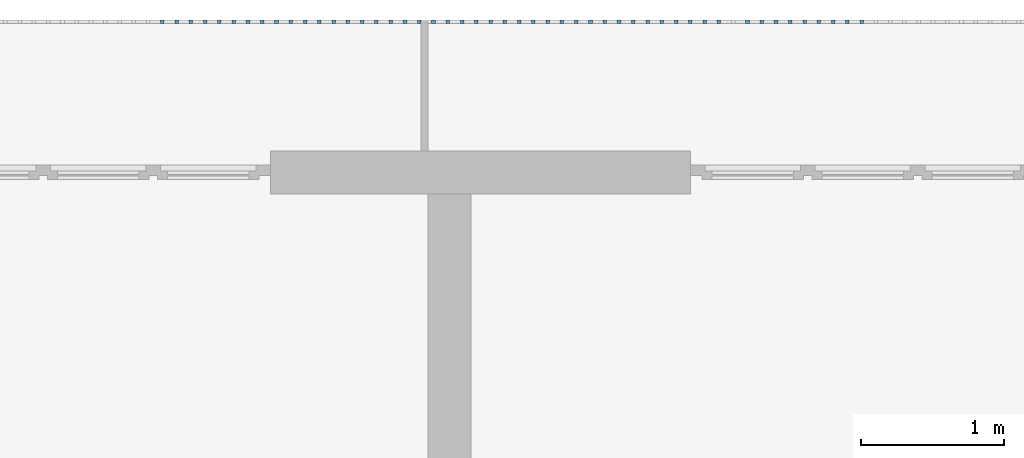
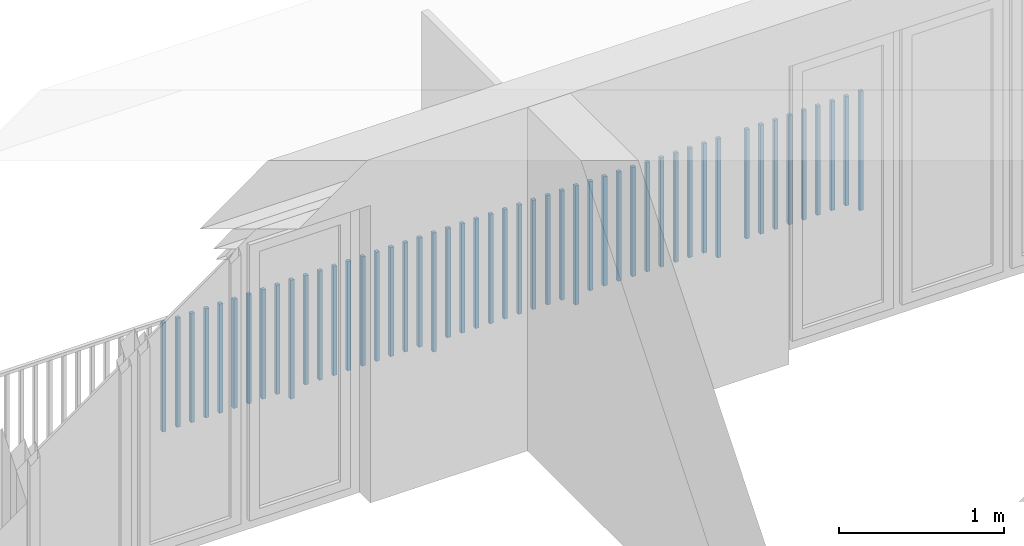
# One storey, part 50 of 54: 49 building element parts, 1 element without a shape of its own.
"""IFC4 building model written with IfcOpenShell, lengths in metres."""

from ifc_helpers import new_model, entity, si_unit, converted_unit, derived_unit, direction, frame, origin_with_axes, place, context, subcontext, project, spatial, polygons, material, type_object, element, aggregate, save


model = new_model("IFC4")

# Units and contexts
model_context = context("Model", 3, precision=1e-05, world=origin_with_axes(), true_north=direction((0.0, 1.0)))
body_context = subcontext(model_context, "Body", "Model", "MODEL_VIEW")
ifc_project = project(units=[si_unit("LENGTHUNIT", "METRE"), si_unit("AREAUNIT", "SQUARE_METRE"), si_unit("VOLUMEUNIT", "CUBIC_METRE"), converted_unit("PLANEANGLEUNIT", "DEGREE", entity("IfcPlaneAngleMeasure", 0.0174532925199), si_unit("PLANEANGLEUNIT", "RADIAN"), dimensions=[0, 0, 0, 0, 0, 0, 0]), converted_unit("TIMEUNIT", "Year", entity("IfcTimeMeasure", 31556926.0), si_unit("TIMEUNIT", "SECOND"), dimensions=[0, 0, 1, 0, 0, 0, 0]), si_unit("MASSUNIT", "GRAM", prefix="KILO"), si_unit("THERMODYNAMICTEMPERATUREUNIT", "DEGREE_CELSIUS"), si_unit("LUMINOUSINTENSITYUNIT", "LUMEN"), si_unit("ENERGYUNIT", "JOULE", prefix="MEGA"), derived_unit("THERMALCONDUCTANCEUNIT", [(si_unit("POWERUNIT", "WATT"), 1), (si_unit("LENGTHUNIT", "METRE"), -1), (si_unit("THERMODYNAMICTEMPERATUREUNIT", "KELVIN"), -1)]), derived_unit("SPECIFICHEATCAPACITYUNIT", [(si_unit("ENERGYUNIT", "JOULE"), 1), (si_unit("MASSUNIT", "GRAM", prefix="KILO"), -1), (si_unit("THERMODYNAMICTEMPERATUREUNIT", "KELVIN"), -1)]), derived_unit("MASSDENSITYUNIT", [(si_unit("MASSUNIT", "GRAM", prefix="KILO"), 1), (si_unit("VOLUMEUNIT", "CUBIC_METRE"), -1)])], contexts=[model_context])

# Site, building, storey, space
site_placement = place(None, origin_with_axes())
site = spatial("IfcSite", under=ifc_project, at=site_placement, CompositionType="ELEMENT")
building_placement = place(site_placement, origin_with_axes())
building = spatial("IfcBuilding", under=site, at=building_placement, CompositionType="ELEMENT")
storey_placement = place(building_placement, frame((0.0, 0.0, 6.29), z_axis=(0.0, 0.0, 1.0), x_axis=(1.0, 0.0, 0.0)))
storey = spatial("IfcBuildingStorey", under=building, at=storey_placement, Name="2. Geschoss", CompositionType="ELEMENT", Elevation=6.29)
space_placement = place(storey_placement, frame((10.2378006196, 9.82118769833, 0.0), z_axis=(0.0, 0.0, 1.0), x_axis=(-1.0, 0.0, 0.0)))
space = spatial("IfcSpace", under=storey, at=space_placement, CompositionType="ELEMENT", PredefinedType="EXTERNAL")

# Railing, building element parts
railing_type = type_object("IfcRailingType", PredefinedType="NOTDEFINED")
railing_placement = place(space_placement, frame((0.0, -7.06315681498e-08, 0.0), z_axis=(0.0, 0.0, 1.0), x_axis=(-1.0, 0.0, 0.0)))
railing = element("IfcRailing", 1, at=railing_placement, inside=space, type_object=railing_type, PredefinedType="NOTDEFINED")
ifc_material = material()
building_element_part_1_placement = place(railing_placement, origin_with_axes())
building_element_part_1 = element("IfcBuildingElementPart", 2, at=building_element_part_1_placement, material=ifc_material, PredefinedType="NOTDEFINED", context=body_context, shape_type="Tessellation", body=[
    polygons([(-7.97076086957, 0.0125, 0.0), (-7.97076086957, -0.0125, 0.0), (-7.97076086957, -0.0125, 0.88), (-7.97076086957, 0.0125, 0.88), (-7.94576086957, 0.0125, 0.0), (-7.94576086957, -0.0125, 0.0), (-7.94576086957, -0.0125, 0.88), (-7.94576086957, 0.0125, 0.88)], [[[1, 2, 3, 4]], [[1, 5, 6, 2]], [[2, 6, 7, 3]], [[4, 3, 7, 8]], [[5, 1, 4, 8]], [[6, 5, 8, 7]]], closed=True),
])
building_element_part_2_placement = place(railing_placement, origin_with_axes())
building_element_part_2 = element("IfcBuildingElementPart", 3, at=building_element_part_2_placement, material=ifc_material, PredefinedType="NOTDEFINED", context=body_context, shape_type="Tessellation", body=[
    polygons([(-8.07023913043, 0.0125, 0.07), (-8.07023913043, -0.0125, 0.07), (-8.07023913043, -0.0125, 0.8775), (-8.07023913043, 0.0125, 0.8775), (-8.04523913043, 0.0125, 0.07), (-8.04523913043, -0.0125, 0.07), (-8.04523913043, -0.0125, 0.8775), (-8.04523913043, 0.0125, 0.8775)], [[[1, 2, 3, 4]], [[1, 5, 6, 2]], [[2, 6, 7, 3]], [[4, 3, 7, 8]], [[5, 1, 4, 8]], [[6, 5, 8, 7]]], closed=True),
])
building_element_part_3_placement = place(railing_placement, origin_with_axes())
building_element_part_3 = element("IfcBuildingElementPart", 4, at=building_element_part_3_placement, material=ifc_material, PredefinedType="NOTDEFINED", context=body_context, shape_type="Tessellation", body=[
    polygons([(-8.1697173913, 0.0125, 0.07), (-8.1697173913, -0.0125, 0.07), (-8.1697173913, -0.0125, 0.8775), (-8.1697173913, 0.0125, 0.8775), (-8.1447173913, 0.0125, 0.07), (-8.1447173913, -0.0125, 0.07), (-8.1447173913, -0.0125, 0.8775), (-8.1447173913, 0.0125, 0.8775)], [[[1, 2, 3, 4]], [[1, 5, 6, 2]], [[2, 6, 7, 3]], [[4, 3, 7, 8]], [[5, 1, 4, 8]], [[6, 5, 8, 7]]], closed=True),
])
building_element_part_4_placement = place(railing_placement, origin_with_axes())
building_element_part_4 = element("IfcBuildingElementPart", 5, at=building_element_part_4_placement, material=ifc_material, PredefinedType="NOTDEFINED", context=body_context, shape_type="Tessellation", body=[
    polygons([(-8.26919565217, 0.0125, 0.07), (-8.26919565217, -0.0125, 0.07), (-8.26919565217, -0.0125, 0.8775), (-8.26919565217, 0.0125, 0.8775), (-8.24419565217, 0.0125, 0.07), (-8.24419565217, -0.0125, 0.07), (-8.24419565217, -0.0125, 0.8775), (-8.24419565217, 0.0125, 0.8775)], [[[1, 2, 3, 4]], [[1, 5, 6, 2]], [[2, 6, 7, 3]], [[4, 3, 7, 8]], [[5, 1, 4, 8]], [[6, 5, 8, 7]]], closed=True),
])
building_element_part_5_placement = place(railing_placement, origin_with_axes())
building_element_part_5 = element("IfcBuildingElementPart", 6, at=building_element_part_5_placement, material=ifc_material, PredefinedType="NOTDEFINED", context=body_context, shape_type="Tessellation", body=[
    polygons([(-8.36867391304, 0.0125, 0.07), (-8.36867391304, -0.0125, 0.07), (-8.36867391304, -0.0125, 0.8775), (-8.36867391304, 0.0125, 0.8775), (-8.34367391304, 0.0125, 0.07), (-8.34367391304, -0.0125, 0.07), (-8.34367391304, -0.0125, 0.8775), (-8.34367391304, 0.0125, 0.8775)], [[[1, 2, 3, 4]], [[1, 5, 6, 2]], [[2, 6, 7, 3]], [[4, 3, 7, 8]], [[5, 1, 4, 8]], [[6, 5, 8, 7]]], closed=True),
])
building_element_part_6_placement = place(railing_placement, origin_with_axes())
building_element_part_6 = element("IfcBuildingElementPart", 7, at=building_element_part_6_placement, material=ifc_material, PredefinedType="NOTDEFINED", context=body_context, shape_type="Tessellation", body=[
    polygons([(-8.46815217391, 0.0125, 0.07), (-8.46815217391, -0.0125, 0.07), (-8.46815217391, -0.0125, 0.8775), (-8.46815217391, 0.0125, 0.8775), (-8.44315217391, 0.0125, 0.07), (-8.44315217391, -0.0125, 0.07), (-8.44315217391, -0.0125, 0.8775), (-8.44315217391, 0.0125, 0.8775)], [[[1, 2, 3, 4]], [[1, 5, 6, 2]], [[2, 6, 7, 3]], [[4, 3, 7, 8]], [[5, 1, 4, 8]], [[6, 5, 8, 7]]], closed=True),
])
building_element_part_7_placement = place(railing_placement, origin_with_axes())
building_element_part_7 = element("IfcBuildingElementPart", 8, at=building_element_part_7_placement, material=ifc_material, PredefinedType="NOTDEFINED", context=body_context, shape_type="Tessellation", body=[
    polygons([(-8.56763043478, 0.0125, 0.07), (-8.56763043478, -0.0125, 0.07), (-8.56763043478, -0.0125, 0.8775), (-8.56763043478, 0.0125, 0.8775), (-8.54263043478, 0.0125, 0.07), (-8.54263043478, -0.0125, 0.07), (-8.54263043478, -0.0125, 0.8775), (-8.54263043478, 0.0125, 0.8775)], [[[1, 2, 3, 4]], [[1, 5, 6, 2]], [[2, 6, 7, 3]], [[4, 3, 7, 8]], [[5, 1, 4, 8]], [[6, 5, 8, 7]]], closed=True),
])
building_element_part_8_placement = place(railing_placement, origin_with_axes())
building_element_part_8 = element("IfcBuildingElementPart", 9, at=building_element_part_8_placement, material=ifc_material, PredefinedType="NOTDEFINED", context=body_context, shape_type="Tessellation", body=[
    polygons([(-8.66710869565, 0.0125, 0.07), (-8.66710869565, -0.0125, 0.07), (-8.66710869565, -0.0125, 0.8775), (-8.66710869565, 0.0125, 0.8775), (-8.64210869565, 0.0125, 0.07), (-8.64210869565, -0.0125, 0.07), (-8.64210869565, -0.0125, 0.8775), (-8.64210869565, 0.0125, 0.8775)], [[[1, 2, 3, 4]], [[1, 5, 6, 2]], [[2, 6, 7, 3]], [[4, 3, 7, 8]], [[5, 1, 4, 8]], [[6, 5, 8, 7]]], closed=True),
])
building_element_part_9_placement = place(railing_placement, origin_with_axes())
building_element_part_9 = element("IfcBuildingElementPart", 10, at=building_element_part_9_placement, material=ifc_material, PredefinedType="NOTDEFINED", context=body_context, shape_type="Tessellation", body=[
    polygons([(-8.76658695652, 0.0125, 0.07), (-8.76658695652, -0.0125, 0.07), (-8.76658695652, -0.0125, 0.8775), (-8.76658695652, 0.0125, 0.8775), (-8.74158695652, 0.0125, 0.07), (-8.74158695652, -0.0125, 0.07), (-8.74158695652, -0.0125, 0.8775), (-8.74158695652, 0.0125, 0.8775)], [[[1, 2, 3, 4]], [[1, 5, 6, 2]], [[2, 6, 7, 3]], [[4, 3, 7, 8]], [[5, 1, 4, 8]], [[6, 5, 8, 7]]], closed=True),
])
building_element_part_10_placement = place(railing_placement, origin_with_axes())
building_element_part_10 = element("IfcBuildingElementPart", 11, at=building_element_part_10_placement, material=ifc_material, PredefinedType="NOTDEFINED", context=body_context, shape_type="Tessellation", body=[
    polygons([(-8.96554347826, 0.0125, 0.0), (-8.96554347826, -0.0125, 0.0), (-8.96554347826, -0.0125, 0.88), (-8.96554347826, 0.0125, 0.88), (-8.94054347826, 0.0125, 0.0), (-8.94054347826, -0.0125, 0.0), (-8.94054347826, -0.0125, 0.88), (-8.94054347826, 0.0125, 0.88)], [[[1, 2, 3, 4]], [[1, 5, 6, 2]], [[2, 6, 7, 3]], [[4, 3, 7, 8]], [[5, 1, 4, 8]], [[6, 5, 8, 7]]], closed=True),
])
building_element_part_11_placement = place(railing_placement, origin_with_axes())
building_element_part_11 = element("IfcBuildingElementPart", 12, at=building_element_part_11_placement, material=ifc_material, PredefinedType="NOTDEFINED", context=body_context, shape_type="Tessellation", body=[
    polygons([(-9.06502173913, 0.0125, 0.07), (-9.06502173913, -0.0125, 0.07), (-9.06502173913, -0.0125, 0.8775), (-9.06502173913, 0.0125, 0.8775), (-9.04002173913, 0.0125, 0.07), (-9.04002173913, -0.0125, 0.07), (-9.04002173913, -0.0125, 0.8775), (-9.04002173913, 0.0125, 0.8775)], [[[1, 2, 3, 4]], [[1, 5, 6, 2]], [[2, 6, 7, 3]], [[4, 3, 7, 8]], [[5, 1, 4, 8]], [[6, 5, 8, 7]]], closed=True),
])
building_element_part_12_placement = place(railing_placement, origin_with_axes())
building_element_part_12 = element("IfcBuildingElementPart", 13, at=building_element_part_12_placement, material=ifc_material, PredefinedType="NOTDEFINED", context=body_context, shape_type="Tessellation", body=[
    polygons([(-9.1645, 0.0125, 0.07), (-9.1645, -0.0125, 0.07), (-9.1645, -0.0125, 0.8775), (-9.1645, 0.0125, 0.8775), (-9.1395, 0.0125, 0.07), (-9.1395, -0.0125, 0.07), (-9.1395, -0.0125, 0.8775), (-9.1395, 0.0125, 0.8775)], [[[1, 2, 3, 4]], [[1, 5, 6, 2]], [[2, 6, 7, 3]], [[4, 3, 7, 8]], [[5, 1, 4, 8]], [[6, 5, 8, 7]]], closed=True),
])
building_element_part_13_placement = place(railing_placement, origin_with_axes())
building_element_part_13 = element("IfcBuildingElementPart", 14, at=building_element_part_13_placement, material=ifc_material, PredefinedType="NOTDEFINED", context=body_context, shape_type="Tessellation", body=[
    polygons([(-9.26397826087, 0.0125, 0.07), (-9.26397826087, -0.0125, 0.07), (-9.26397826087, -0.0125, 0.8775), (-9.26397826087, 0.0125, 0.8775), (-9.23897826087, 0.0125, 0.07), (-9.23897826087, -0.0125, 0.07), (-9.23897826087, -0.0125, 0.8775), (-9.23897826087, 0.0125, 0.8775)], [[[1, 2, 3, 4]], [[1, 5, 6, 2]], [[2, 6, 7, 3]], [[4, 3, 7, 8]], [[5, 1, 4, 8]], [[6, 5, 8, 7]]], closed=True),
])
building_element_part_14_placement = place(railing_placement, origin_with_axes())
building_element_part_14 = element("IfcBuildingElementPart", 15, at=building_element_part_14_placement, material=ifc_material, PredefinedType="NOTDEFINED", context=body_context, shape_type="Tessellation", body=[
    polygons([(-9.36345652174, 0.0125, 0.07), (-9.36345652174, -0.0125, 0.07), (-9.36345652174, -0.0125, 0.8775), (-9.36345652174, 0.0125, 0.8775), (-9.33845652174, 0.0125, 0.07), (-9.33845652174, -0.0125, 0.07), (-9.33845652174, -0.0125, 0.8775), (-9.33845652174, 0.0125, 0.8775)], [[[1, 2, 3, 4]], [[1, 5, 6, 2]], [[2, 6, 7, 3]], [[4, 3, 7, 8]], [[5, 1, 4, 8]], [[6, 5, 8, 7]]], closed=True),
])
building_element_part_15_placement = place(railing_placement, origin_with_axes())
building_element_part_15 = element("IfcBuildingElementPart", 16, at=building_element_part_15_placement, material=ifc_material, PredefinedType="NOTDEFINED", context=body_context, shape_type="Tessellation", body=[
    polygons([(-9.46293478261, 0.0125, 0.07), (-9.46293478261, -0.0125, 0.07), (-9.46293478261, -0.0125, 0.8775), (-9.46293478261, 0.0125, 0.8775), (-9.43793478261, 0.0125, 0.07), (-9.43793478261, -0.0125, 0.07), (-9.43793478261, -0.0125, 0.8775), (-9.43793478261, 0.0125, 0.8775)], [[[1, 2, 3, 4]], [[1, 5, 6, 2]], [[2, 6, 7, 3]], [[4, 3, 7, 8]], [[5, 1, 4, 8]], [[6, 5, 8, 7]]], closed=True),
])
building_element_part_16_placement = place(railing_placement, origin_with_axes())
building_element_part_16 = element("IfcBuildingElementPart", 17, at=building_element_part_16_placement, material=ifc_material, PredefinedType="NOTDEFINED", context=body_context, shape_type="Tessellation", body=[
    polygons([(-9.56241304348, 0.0125, 0.07), (-9.56241304348, -0.0125, 0.07), (-9.56241304348, -0.0125, 0.8775), (-9.56241304348, 0.0125, 0.8775), (-9.53741304348, 0.0125, 0.07), (-9.53741304348, -0.0125, 0.07), (-9.53741304348, -0.0125, 0.8775), (-9.53741304348, 0.0125, 0.8775)], [[[1, 2, 3, 4]], [[1, 5, 6, 2]], [[2, 6, 7, 3]], [[4, 3, 7, 8]], [[5, 1, 4, 8]], [[6, 5, 8, 7]]], closed=True),
])
building_element_part_17_placement = place(railing_placement, origin_with_axes())
building_element_part_17 = element("IfcBuildingElementPart", 18, at=building_element_part_17_placement, material=ifc_material, PredefinedType="NOTDEFINED", context=body_context, shape_type="Tessellation", body=[
    polygons([(-9.66189130435, 0.0125, 0.07), (-9.66189130435, -0.0125, 0.07), (-9.66189130435, -0.0125, 0.8775), (-9.66189130435, 0.0125, 0.8775), (-9.63689130435, 0.0125, 0.07), (-9.63689130435, -0.0125, 0.07), (-9.63689130435, -0.0125, 0.8775), (-9.63689130435, 0.0125, 0.8775)], [[[1, 2, 3, 4]], [[1, 5, 6, 2]], [[2, 6, 7, 3]], [[4, 3, 7, 8]], [[5, 1, 4, 8]], [[6, 5, 8, 7]]], closed=True),
])
building_element_part_18_placement = place(railing_placement, origin_with_axes())
building_element_part_18 = element("IfcBuildingElementPart", 19, at=building_element_part_18_placement, material=ifc_material, PredefinedType="NOTDEFINED", context=body_context, shape_type="Tessellation", body=[
    polygons([(-9.76136956522, 0.0125, 0.07), (-9.76136956522, -0.0125, 0.07), (-9.76136956522, -0.0125, 0.8775), (-9.76136956522, 0.0125, 0.8775), (-9.73636956522, 0.0125, 0.07), (-9.73636956522, -0.0125, 0.07), (-9.73636956522, -0.0125, 0.8775), (-9.73636956522, 0.0125, 0.8775)], [[[1, 2, 3, 4]], [[1, 5, 6, 2]], [[2, 6, 7, 3]], [[4, 3, 7, 8]], [[5, 1, 4, 8]], [[6, 5, 8, 7]]], closed=True),
])
building_element_part_19_placement = place(railing_placement, origin_with_axes())
building_element_part_19 = element("IfcBuildingElementPart", 20, at=building_element_part_19_placement, material=ifc_material, PredefinedType="NOTDEFINED", context=body_context, shape_type="Tessellation", body=[
    polygons([(-9.86084782609, 0.0125, 0.07), (-9.86084782609, -0.0125, 0.07), (-9.86084782609, -0.0125, 0.8775), (-9.86084782609, 0.0125, 0.8775), (-9.83584782609, 0.0125, 0.07), (-9.83584782609, -0.0125, 0.07), (-9.83584782609, -0.0125, 0.8775), (-9.83584782609, 0.0125, 0.8775)], [[[1, 2, 3, 4]], [[1, 5, 6, 2]], [[2, 6, 7, 3]], [[4, 3, 7, 8]], [[5, 1, 4, 8]], [[6, 5, 8, 7]]], closed=True),
])
building_element_part_20_placement = place(railing_placement, origin_with_axes())
building_element_part_20 = element("IfcBuildingElementPart", 21, at=building_element_part_20_placement, material=ifc_material, PredefinedType="NOTDEFINED", context=body_context, shape_type="Tessellation", body=[
    polygons([(-9.96032608696, 0.0125, 0.0), (-9.96032608696, -0.0125, 0.0), (-9.96032608696, -0.0125, 0.88), (-9.96032608696, 0.0125, 0.88), (-9.93532608696, 0.0125, 0.0), (-9.93532608696, -0.0125, 0.0), (-9.93532608696, -0.0125, 0.88), (-9.93532608696, 0.0125, 0.88)], [[[1, 2, 3, 4]], [[1, 5, 6, 2]], [[2, 6, 7, 3]], [[4, 3, 7, 8]], [[5, 1, 4, 8]], [[6, 5, 8, 7]]], closed=True),
])
building_element_part_21_placement = place(railing_placement, origin_with_axes())
building_element_part_21 = element("IfcBuildingElementPart", 22, at=building_element_part_21_placement, material=ifc_material, PredefinedType="NOTDEFINED", context=body_context, shape_type="Tessellation", body=[
    polygons([(-10.0598043478, 0.0125, 0.07), (-10.0598043478, -0.0125, 0.07), (-10.0598043478, -0.0125, 0.8775), (-10.0598043478, 0.0125, 0.8775), (-10.0348043478, 0.0125, 0.07), (-10.0348043478, -0.0125, 0.07), (-10.0348043478, -0.0125, 0.8775), (-10.0348043478, 0.0125, 0.8775)], [[[1, 2, 3, 4]], [[1, 5, 6, 2]], [[2, 6, 7, 3]], [[4, 3, 7, 8]], [[5, 1, 4, 8]], [[6, 5, 8, 7]]], closed=True),
])
building_element_part_22_placement = place(railing_placement, origin_with_axes())
building_element_part_22 = element("IfcBuildingElementPart", 23, at=building_element_part_22_placement, material=ifc_material, PredefinedType="NOTDEFINED", context=body_context, shape_type="Tessellation", body=[
    polygons([(-10.1592826087, 0.0125, 0.07), (-10.1592826087, -0.0125, 0.07), (-10.1592826087, -0.0125, 0.8775), (-10.1592826087, 0.0125, 0.8775), (-10.1342826087, 0.0125, 0.07), (-10.1342826087, -0.0125, 0.07), (-10.1342826087, -0.0125, 0.8775), (-10.1342826087, 0.0125, 0.8775)], [[[1, 2, 3, 4]], [[1, 5, 6, 2]], [[2, 6, 7, 3]], [[4, 3, 7, 8]], [[5, 1, 4, 8]], [[6, 5, 8, 7]]], closed=True),
])
building_element_part_23_placement = place(railing_placement, origin_with_axes())
building_element_part_23 = element("IfcBuildingElementPart", 24, at=building_element_part_23_placement, material=ifc_material, PredefinedType="NOTDEFINED", context=body_context, shape_type="Tessellation", body=[
    polygons([(-10.2587608696, 0.0125, 0.07), (-10.2587608696, -0.0125, 0.07), (-10.2587608696, -0.0125, 0.8775), (-10.2587608696, 0.0125, 0.8775), (-10.2337608696, 0.0125, 0.07), (-10.2337608696, -0.0125, 0.07), (-10.2337608696, -0.0125, 0.8775), (-10.2337608696, 0.0125, 0.8775)], [[[1, 2, 3, 4]], [[1, 5, 6, 2]], [[2, 6, 7, 3]], [[4, 3, 7, 8]], [[5, 1, 4, 8]], [[6, 5, 8, 7]]], closed=True),
])
building_element_part_24_placement = place(railing_placement, origin_with_axes())
building_element_part_24 = element("IfcBuildingElementPart", 25, at=building_element_part_24_placement, material=ifc_material, PredefinedType="NOTDEFINED", context=body_context, shape_type="Tessellation", body=[
    polygons([(-10.3582391304, 0.0125, 0.07), (-10.3582391304, -0.0125, 0.07), (-10.3582391304, -0.0125, 0.8775), (-10.3582391304, 0.0125, 0.8775), (-10.3332391304, 0.0125, 0.07), (-10.3332391304, -0.0125, 0.07), (-10.3332391304, -0.0125, 0.8775), (-10.3332391304, 0.0125, 0.8775)], [[[1, 2, 3, 4]], [[1, 5, 6, 2]], [[2, 6, 7, 3]], [[4, 3, 7, 8]], [[5, 1, 4, 8]], [[6, 5, 8, 7]]], closed=True),
])
building_element_part_25_placement = place(railing_placement, origin_with_axes())
building_element_part_25 = element("IfcBuildingElementPart", 26, at=building_element_part_25_placement, material=ifc_material, PredefinedType="NOTDEFINED", context=body_context, shape_type="Tessellation", body=[
    polygons([(-10.4577173913, 0.0125, 0.07), (-10.4577173913, -0.0125, 0.07), (-10.4577173913, -0.0125, 0.8775), (-10.4577173913, 0.0125, 0.8775), (-10.4327173913, 0.0125, 0.07), (-10.4327173913, -0.0125, 0.07), (-10.4327173913, -0.0125, 0.8775), (-10.4327173913, 0.0125, 0.8775)], [[[1, 2, 3, 4]], [[1, 5, 6, 2]], [[2, 6, 7, 3]], [[4, 3, 7, 8]], [[5, 1, 4, 8]], [[6, 5, 8, 7]]], closed=True),
])
building_element_part_26_placement = place(railing_placement, origin_with_axes())
building_element_part_26 = element("IfcBuildingElementPart", 27, at=building_element_part_26_placement, material=ifc_material, PredefinedType="NOTDEFINED", context=body_context, shape_type="Tessellation", body=[
    polygons([(-10.5571956522, 0.0125, 0.07), (-10.5571956522, -0.0125, 0.07), (-10.5571956522, -0.0125, 0.8775), (-10.5571956522, 0.0125, 0.8775), (-10.5321956522, 0.0125, 0.07), (-10.5321956522, -0.0125, 0.07), (-10.5321956522, -0.0125, 0.8775), (-10.5321956522, 0.0125, 0.8775)], [[[1, 2, 3, 4]], [[1, 5, 6, 2]], [[2, 6, 7, 3]], [[4, 3, 7, 8]], [[5, 1, 4, 8]], [[6, 5, 8, 7]]], closed=True),
])
building_element_part_27_placement = place(railing_placement, origin_with_axes())
building_element_part_27 = element("IfcBuildingElementPart", 28, at=building_element_part_27_placement, material=ifc_material, PredefinedType="NOTDEFINED", context=body_context, shape_type="Tessellation", body=[
    polygons([(-10.656673913, 0.0125, 0.07), (-10.656673913, -0.0125, 0.07), (-10.656673913, -0.0125, 0.8775), (-10.656673913, 0.0125, 0.8775), (-10.631673913, 0.0125, 0.07), (-10.631673913, -0.0125, 0.07), (-10.631673913, -0.0125, 0.8775), (-10.631673913, 0.0125, 0.8775)], [[[1, 2, 3, 4]], [[1, 5, 6, 2]], [[2, 6, 7, 3]], [[4, 3, 7, 8]], [[5, 1, 4, 8]], [[6, 5, 8, 7]]], closed=True),
])
building_element_part_28_placement = place(railing_placement, origin_with_axes())
building_element_part_28 = element("IfcBuildingElementPart", 29, at=building_element_part_28_placement, material=ifc_material, PredefinedType="NOTDEFINED", context=body_context, shape_type="Tessellation", body=[
    polygons([(-10.7561521739, 0.0125, 0.07), (-10.7561521739, -0.0125, 0.07), (-10.7561521739, -0.0125, 0.8775), (-10.7561521739, 0.0125, 0.8775), (-10.7311521739, 0.0125, 0.07), (-10.7311521739, -0.0125, 0.07), (-10.7311521739, -0.0125, 0.8775), (-10.7311521739, 0.0125, 0.8775)], [[[1, 2, 3, 4]], [[1, 5, 6, 2]], [[2, 6, 7, 3]], [[4, 3, 7, 8]], [[5, 1, 4, 8]], [[6, 5, 8, 7]]], closed=True),
])
building_element_part_29_placement = place(railing_placement, origin_with_axes())
building_element_part_29 = element("IfcBuildingElementPart", 30, at=building_element_part_29_placement, material=ifc_material, PredefinedType="NOTDEFINED", context=body_context, shape_type="Tessellation", body=[
    polygons([(-10.8556304348, 0.0125, 0.07), (-10.8556304348, -0.0125, 0.07), (-10.8556304348, -0.0125, 0.8775), (-10.8556304348, 0.0125, 0.8775), (-10.8306304348, 0.0125, 0.07), (-10.8306304348, -0.0125, 0.07), (-10.8306304348, -0.0125, 0.8775), (-10.8306304348, 0.0125, 0.8775)], [[[1, 2, 3, 4]], [[1, 5, 6, 2]], [[2, 6, 7, 3]], [[4, 3, 7, 8]], [[5, 1, 4, 8]], [[6, 5, 8, 7]]], closed=True),
])
building_element_part_30_placement = place(railing_placement, origin_with_axes())
building_element_part_30 = element("IfcBuildingElementPart", 31, at=building_element_part_30_placement, material=ifc_material, PredefinedType="NOTDEFINED", context=body_context, shape_type="Tessellation", body=[
    polygons([(-10.9551086957, 0.0125, 0.0), (-10.9551086957, -0.0125, 0.0), (-10.9551086957, -0.0125, 0.88), (-10.9551086957, 0.0125, 0.88), (-10.9301086957, 0.0125, 0.0), (-10.9301086957, -0.0125, 0.0), (-10.9301086957, -0.0125, 0.88), (-10.9301086957, 0.0125, 0.88)], [[[1, 2, 3, 4]], [[1, 5, 6, 2]], [[2, 6, 7, 3]], [[4, 3, 7, 8]], [[5, 1, 4, 8]], [[6, 5, 8, 7]]], closed=True),
])
building_element_part_31_placement = place(railing_placement, origin_with_axes())
building_element_part_31 = element("IfcBuildingElementPart", 32, at=building_element_part_31_placement, material=ifc_material, PredefinedType="NOTDEFINED", context=body_context, shape_type="Tessellation", body=[
    polygons([(-11.0545869565, 0.0125, 0.07), (-11.0545869565, -0.0125, 0.07), (-11.0545869565, -0.0125, 0.8775), (-11.0545869565, 0.0125, 0.8775), (-11.0295869565, 0.0125, 0.07), (-11.0295869565, -0.0125, 0.07), (-11.0295869565, -0.0125, 0.8775), (-11.0295869565, 0.0125, 0.8775)], [[[1, 2, 3, 4]], [[1, 5, 6, 2]], [[2, 6, 7, 3]], [[4, 3, 7, 8]], [[5, 1, 4, 8]], [[6, 5, 8, 7]]], closed=True),
])
building_element_part_32_placement = place(railing_placement, origin_with_axes())
building_element_part_32 = element("IfcBuildingElementPart", 33, at=building_element_part_32_placement, material=ifc_material, PredefinedType="NOTDEFINED", context=body_context, shape_type="Tessellation", body=[
    polygons([(-11.1540652174, 0.0125, 0.07), (-11.1540652174, -0.0125, 0.07), (-11.1540652174, -0.0125, 0.8775), (-11.1540652174, 0.0125, 0.8775), (-11.1290652174, 0.0125, 0.07), (-11.1290652174, -0.0125, 0.07), (-11.1290652174, -0.0125, 0.8775), (-11.1290652174, 0.0125, 0.8775)], [[[1, 2, 3, 4]], [[1, 5, 6, 2]], [[2, 6, 7, 3]], [[4, 3, 7, 8]], [[5, 1, 4, 8]], [[6, 5, 8, 7]]], closed=True),
])
building_element_part_33_placement = place(railing_placement, origin_with_axes())
building_element_part_33 = element("IfcBuildingElementPart", 34, at=building_element_part_33_placement, material=ifc_material, PredefinedType="NOTDEFINED", context=body_context, shape_type="Tessellation", body=[
    polygons([(-11.2535434783, 0.0125, 0.07), (-11.2535434783, -0.0125, 0.07), (-11.2535434783, -0.0125, 0.8775), (-11.2535434783, 0.0125, 0.8775), (-11.2285434783, 0.0125, 0.07), (-11.2285434783, -0.0125, 0.07), (-11.2285434783, -0.0125, 0.8775), (-11.2285434783, 0.0125, 0.8775)], [[[1, 2, 3, 4]], [[1, 5, 6, 2]], [[2, 6, 7, 3]], [[4, 3, 7, 8]], [[5, 1, 4, 8]], [[6, 5, 8, 7]]], closed=True),
])
building_element_part_34_placement = place(railing_placement, origin_with_axes())
building_element_part_34 = element("IfcBuildingElementPart", 35, at=building_element_part_34_placement, material=ifc_material, PredefinedType="NOTDEFINED", context=body_context, shape_type="Tessellation", body=[
    polygons([(-11.3530217391, 0.0125, 0.07), (-11.3530217391, -0.0125, 0.07), (-11.3530217391, -0.0125, 0.8775), (-11.3530217391, 0.0125, 0.8775), (-11.3280217391, 0.0125, 0.07), (-11.3280217391, -0.0125, 0.07), (-11.3280217391, -0.0125, 0.8775), (-11.3280217391, 0.0125, 0.8775)], [[[1, 2, 3, 4]], [[1, 5, 6, 2]], [[2, 6, 7, 3]], [[4, 3, 7, 8]], [[5, 1, 4, 8]], [[6, 5, 8, 7]]], closed=True),
])
building_element_part_35_placement = place(railing_placement, origin_with_axes())
building_element_part_35 = element("IfcBuildingElementPart", 36, at=building_element_part_35_placement, material=ifc_material, PredefinedType="NOTDEFINED", context=body_context, shape_type="Tessellation", body=[
    polygons([(-11.4525, 0.0125, 0.07), (-11.4525, -0.0125, 0.07), (-11.4525, -0.0125, 0.8775), (-11.4525, 0.0125, 0.8775), (-11.4275, 0.0125, 0.07), (-11.4275, -0.0125, 0.07), (-11.4275, -0.0125, 0.8775), (-11.4275, 0.0125, 0.8775)], [[[1, 2, 3, 4]], [[1, 5, 6, 2]], [[2, 6, 7, 3]], [[4, 3, 7, 8]], [[5, 1, 4, 8]], [[6, 5, 8, 7]]], closed=True),
])
building_element_part_36_placement = place(railing_placement, origin_with_axes())
building_element_part_36 = element("IfcBuildingElementPart", 37, at=building_element_part_36_placement, material=ifc_material, PredefinedType="NOTDEFINED", context=body_context, shape_type="Tessellation", body=[
    polygons([(-11.5519782609, 0.0125, 0.07), (-11.5519782609, -0.0125, 0.07), (-11.5519782609, -0.0125, 0.8775), (-11.5519782609, 0.0125, 0.8775), (-11.5269782609, 0.0125, 0.07), (-11.5269782609, -0.0125, 0.07), (-11.5269782609, -0.0125, 0.8775), (-11.5269782609, 0.0125, 0.8775)], [[[1, 2, 3, 4]], [[1, 5, 6, 2]], [[2, 6, 7, 3]], [[4, 3, 7, 8]], [[5, 1, 4, 8]], [[6, 5, 8, 7]]], closed=True),
])
building_element_part_37_placement = place(railing_placement, origin_with_axes())
building_element_part_37 = element("IfcBuildingElementPart", 38, at=building_element_part_37_placement, material=ifc_material, PredefinedType="NOTDEFINED", context=body_context, shape_type="Tessellation", body=[
    polygons([(-11.6514565217, 0.0125, 0.07), (-11.6514565217, -0.0125, 0.07), (-11.6514565217, -0.0125, 0.8775), (-11.6514565217, 0.0125, 0.8775), (-11.6264565217, 0.0125, 0.07), (-11.6264565217, -0.0125, 0.07), (-11.6264565217, -0.0125, 0.8775), (-11.6264565217, 0.0125, 0.8775)], [[[1, 2, 3, 4]], [[1, 5, 6, 2]], [[2, 6, 7, 3]], [[4, 3, 7, 8]], [[5, 1, 4, 8]], [[6, 5, 8, 7]]], closed=True),
])
building_element_part_38_placement = place(railing_placement, origin_with_axes())
building_element_part_38 = element("IfcBuildingElementPart", 39, at=building_element_part_38_placement, material=ifc_material, PredefinedType="NOTDEFINED", context=body_context, shape_type="Tessellation", body=[
    polygons([(-11.7509347826, 0.0125, 0.07), (-11.7509347826, -0.0125, 0.07), (-11.7509347826, -0.0125, 0.8775), (-11.7509347826, 0.0125, 0.8775), (-11.7259347826, 0.0125, 0.07), (-11.7259347826, -0.0125, 0.07), (-11.7259347826, -0.0125, 0.8775), (-11.7259347826, 0.0125, 0.8775)], [[[1, 2, 3, 4]], [[1, 5, 6, 2]], [[2, 6, 7, 3]], [[4, 3, 7, 8]], [[5, 1, 4, 8]], [[6, 5, 8, 7]]], closed=True),
])
building_element_part_39_placement = place(railing_placement, origin_with_axes())
building_element_part_39 = element("IfcBuildingElementPart", 40, at=building_element_part_39_placement, material=ifc_material, PredefinedType="NOTDEFINED", context=body_context, shape_type="Tessellation", body=[
    polygons([(-11.8504130435, 0.0125, 0.07), (-11.8504130435, -0.0125, 0.07), (-11.8504130435, -0.0125, 0.8775), (-11.8504130435, 0.0125, 0.8775), (-11.8254130435, 0.0125, 0.07), (-11.8254130435, -0.0125, 0.07), (-11.8254130435, -0.0125, 0.8775), (-11.8254130435, 0.0125, 0.8775)], [[[1, 2, 3, 4]], [[1, 5, 6, 2]], [[2, 6, 7, 3]], [[4, 3, 7, 8]], [[5, 1, 4, 8]], [[6, 5, 8, 7]]], closed=True),
])
building_element_part_40_placement = place(railing_placement, origin_with_axes())
building_element_part_40 = element("IfcBuildingElementPart", 41, at=building_element_part_40_placement, material=ifc_material, PredefinedType="NOTDEFINED", context=body_context, shape_type="Tessellation", body=[
    polygons([(-11.9498913043, 0.0125, 0.0), (-11.9498913043, -0.0125, 0.0), (-11.9498913043, -0.0125, 0.88), (-11.9498913043, 0.0125, 0.88), (-11.9248913043, 0.0125, 0.0), (-11.9248913043, -0.0125, 0.0), (-11.9248913043, -0.0125, 0.88), (-11.9248913043, 0.0125, 0.88)], [[[1, 2, 3, 4]], [[1, 5, 6, 2]], [[2, 6, 7, 3]], [[4, 3, 7, 8]], [[5, 1, 4, 8]], [[6, 5, 8, 7]]], closed=True),
])
building_element_part_41_placement = place(railing_placement, origin_with_axes())
building_element_part_41 = element("IfcBuildingElementPart", 42, at=building_element_part_41_placement, material=ifc_material, PredefinedType="NOTDEFINED", context=body_context, shape_type="Tessellation", body=[
    polygons([(-12.0493695652, 0.0125, 0.07), (-12.0493695652, -0.0125, 0.07), (-12.0493695652, -0.0125, 0.8775), (-12.0493695652, 0.0125, 0.8775), (-12.0243695652, 0.0125, 0.07), (-12.0243695652, -0.0125, 0.07), (-12.0243695652, -0.0125, 0.8775), (-12.0243695652, 0.0125, 0.8775)], [[[1, 2, 3, 4]], [[1, 5, 6, 2]], [[2, 6, 7, 3]], [[4, 3, 7, 8]], [[5, 1, 4, 8]], [[6, 5, 8, 7]]], closed=True),
])
building_element_part_42_placement = place(railing_placement, origin_with_axes())
building_element_part_42 = element("IfcBuildingElementPart", 43, at=building_element_part_42_placement, material=ifc_material, PredefinedType="NOTDEFINED", context=body_context, shape_type="Tessellation", body=[
    polygons([(-12.1488478261, 0.0125, 0.07), (-12.1488478261, -0.0125, 0.07), (-12.1488478261, -0.0125, 0.8775), (-12.1488478261, 0.0125, 0.8775), (-12.1238478261, 0.0125, 0.07), (-12.1238478261, -0.0125, 0.07), (-12.1238478261, -0.0125, 0.8775), (-12.1238478261, 0.0125, 0.8775)], [[[1, 2, 3, 4]], [[1, 5, 6, 2]], [[2, 6, 7, 3]], [[4, 3, 7, 8]], [[5, 1, 4, 8]], [[6, 5, 8, 7]]], closed=True),
])
building_element_part_43_placement = place(railing_placement, origin_with_axes())
building_element_part_43 = element("IfcBuildingElementPart", 44, at=building_element_part_43_placement, material=ifc_material, PredefinedType="NOTDEFINED", context=body_context, shape_type="Tessellation", body=[
    polygons([(-12.248326087, 0.0125, 0.07), (-12.248326087, -0.0125, 0.07), (-12.248326087, -0.0125, 0.8775), (-12.248326087, 0.0125, 0.8775), (-12.223326087, 0.0125, 0.07), (-12.223326087, -0.0125, 0.07), (-12.223326087, -0.0125, 0.8775), (-12.223326087, 0.0125, 0.8775)], [[[1, 2, 3, 4]], [[1, 5, 6, 2]], [[2, 6, 7, 3]], [[4, 3, 7, 8]], [[5, 1, 4, 8]], [[6, 5, 8, 7]]], closed=True),
])
building_element_part_44_placement = place(railing_placement, origin_with_axes())
building_element_part_44 = element("IfcBuildingElementPart", 45, at=building_element_part_44_placement, material=ifc_material, PredefinedType="NOTDEFINED", context=body_context, shape_type="Tessellation", body=[
    polygons([(-12.3478043478, 0.0125, 0.07), (-12.3478043478, -0.0125, 0.07), (-12.3478043478, -0.0125, 0.8775), (-12.3478043478, 0.0125, 0.8775), (-12.3228043478, 0.0125, 0.07), (-12.3228043478, -0.0125, 0.07), (-12.3228043478, -0.0125, 0.8775), (-12.3228043478, 0.0125, 0.8775)], [[[1, 2, 3, 4]], [[1, 5, 6, 2]], [[2, 6, 7, 3]], [[4, 3, 7, 8]], [[5, 1, 4, 8]], [[6, 5, 8, 7]]], closed=True),
])
building_element_part_45_placement = place(railing_placement, origin_with_axes())
building_element_part_45 = element("IfcBuildingElementPart", 46, at=building_element_part_45_placement, material=ifc_material, PredefinedType="NOTDEFINED", context=body_context, shape_type="Tessellation", body=[
    polygons([(-12.4472826087, 0.0125, 0.07), (-12.4472826087, -0.0125, 0.07), (-12.4472826087, -0.0125, 0.8775), (-12.4472826087, 0.0125, 0.8775), (-12.4222826087, 0.0125, 0.07), (-12.4222826087, -0.0125, 0.07), (-12.4222826087, -0.0125, 0.8775), (-12.4222826087, 0.0125, 0.8775)], [[[1, 2, 3, 4]], [[1, 5, 6, 2]], [[2, 6, 7, 3]], [[4, 3, 7, 8]], [[5, 1, 4, 8]], [[6, 5, 8, 7]]], closed=True),
])
building_element_part_46_placement = place(railing_placement, origin_with_axes())
building_element_part_46 = element("IfcBuildingElementPart", 47, at=building_element_part_46_placement, material=ifc_material, PredefinedType="NOTDEFINED", context=body_context, shape_type="Tessellation", body=[
    polygons([(-12.5467608696, 0.0125, 0.07), (-12.5467608696, -0.0125, 0.07), (-12.5467608696, -0.0125, 0.8775), (-12.5467608696, 0.0125, 0.8775), (-12.5217608696, 0.0125, 0.07), (-12.5217608696, -0.0125, 0.07), (-12.5217608696, -0.0125, 0.8775), (-12.5217608696, 0.0125, 0.8775)], [[[1, 2, 3, 4]], [[1, 5, 6, 2]], [[2, 6, 7, 3]], [[4, 3, 7, 8]], [[5, 1, 4, 8]], [[6, 5, 8, 7]]], closed=True),
])
building_element_part_47_placement = place(railing_placement, origin_with_axes())
building_element_part_47 = element("IfcBuildingElementPart", 48, at=building_element_part_47_placement, material=ifc_material, PredefinedType="NOTDEFINED", context=body_context, shape_type="Tessellation", body=[
    polygons([(-12.6462391304, 0.0125, 0.07), (-12.6462391304, -0.0125, 0.07), (-12.6462391304, -0.0125, 0.8775), (-12.6462391304, 0.0125, 0.8775), (-12.6212391304, 0.0125, 0.07), (-12.6212391304, -0.0125, 0.07), (-12.6212391304, -0.0125, 0.8775), (-12.6212391304, 0.0125, 0.8775)], [[[1, 2, 3, 4]], [[1, 5, 6, 2]], [[2, 6, 7, 3]], [[4, 3, 7, 8]], [[5, 1, 4, 8]], [[6, 5, 8, 7]]], closed=True),
])
building_element_part_48_placement = place(railing_placement, origin_with_axes())
building_element_part_48 = element("IfcBuildingElementPart", 49, at=building_element_part_48_placement, material=ifc_material, PredefinedType="NOTDEFINED", context=body_context, shape_type="Tessellation", body=[
    polygons([(-12.7457173913, 0.0125, 0.07), (-12.7457173913, -0.0125, 0.07), (-12.7457173913, -0.0125, 0.8775), (-12.7457173913, 0.0125, 0.8775), (-12.7207173913, 0.0125, 0.07), (-12.7207173913, -0.0125, 0.07), (-12.7207173913, -0.0125, 0.8775), (-12.7207173913, 0.0125, 0.8775)], [[[1, 2, 3, 4]], [[1, 5, 6, 2]], [[2, 6, 7, 3]], [[4, 3, 7, 8]], [[5, 1, 4, 8]], [[6, 5, 8, 7]]], closed=True),
])
building_element_part_49_placement = place(railing_placement, origin_with_axes())
building_element_part_49 = element("IfcBuildingElementPart", 50, at=building_element_part_49_placement, material=ifc_material, PredefinedType="NOTDEFINED", context=body_context, shape_type="Tessellation", body=[
    polygons([(-12.8451956522, 0.0125, 0.07), (-12.8451956522, -0.0125, 0.07), (-12.8451956522, -0.0125, 0.8775), (-12.8451956522, 0.0125, 0.8775), (-12.8201956522, 0.0125, 0.07), (-12.8201956522, -0.0125, 0.07), (-12.8201956522, -0.0125, 0.8775), (-12.8201956522, 0.0125, 0.8775)], [[[1, 2, 3, 4]], [[1, 5, 6, 2]], [[2, 6, 7, 3]], [[4, 3, 7, 8]], [[5, 1, 4, 8]], [[6, 5, 8, 7]]], closed=True),
])
aggregate(railing, [building_element_part_1, building_element_part_2, building_element_part_3, building_element_part_4, building_element_part_5, building_element_part_6, building_element_part_7, building_element_part_8, building_element_part_9, building_element_part_10, building_element_part_11, building_element_part_12, building_element_part_13, building_element_part_14, building_element_part_15, building_element_part_16, building_element_part_17, building_element_part_18, building_element_part_19, building_element_part_20, building_element_part_21, building_element_part_22, building_element_part_23, building_element_part_24, building_element_part_25, building_element_part_26, building_element_part_27, building_element_part_28, building_element_part_29, building_element_part_30, building_element_part_31, building_element_part_32, building_element_part_33, building_element_part_34, building_element_part_35, building_element_part_36, building_element_part_37, building_element_part_38, building_element_part_39, building_element_part_40, building_element_part_41, building_element_part_42, building_element_part_43, building_element_part_44, building_element_part_45, building_element_part_46, building_element_part_47, building_element_part_48, building_element_part_49])

save(model, "model.ifc")
